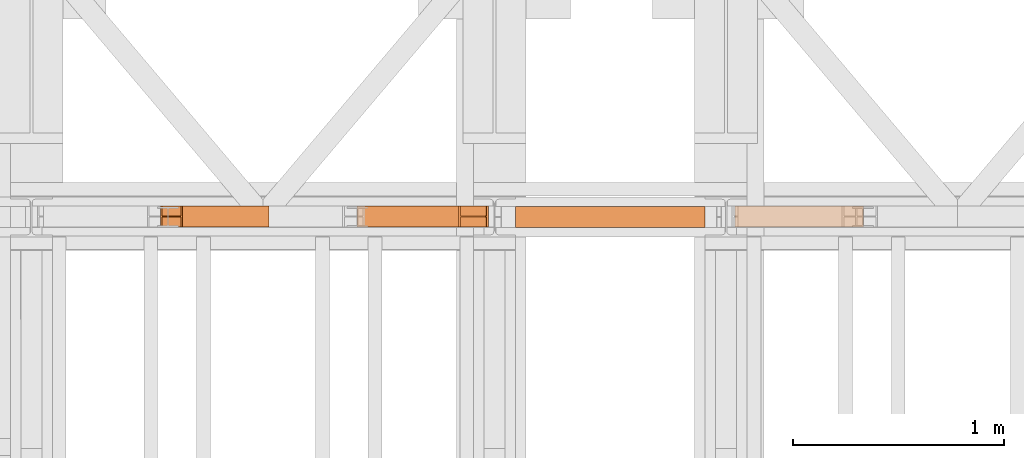
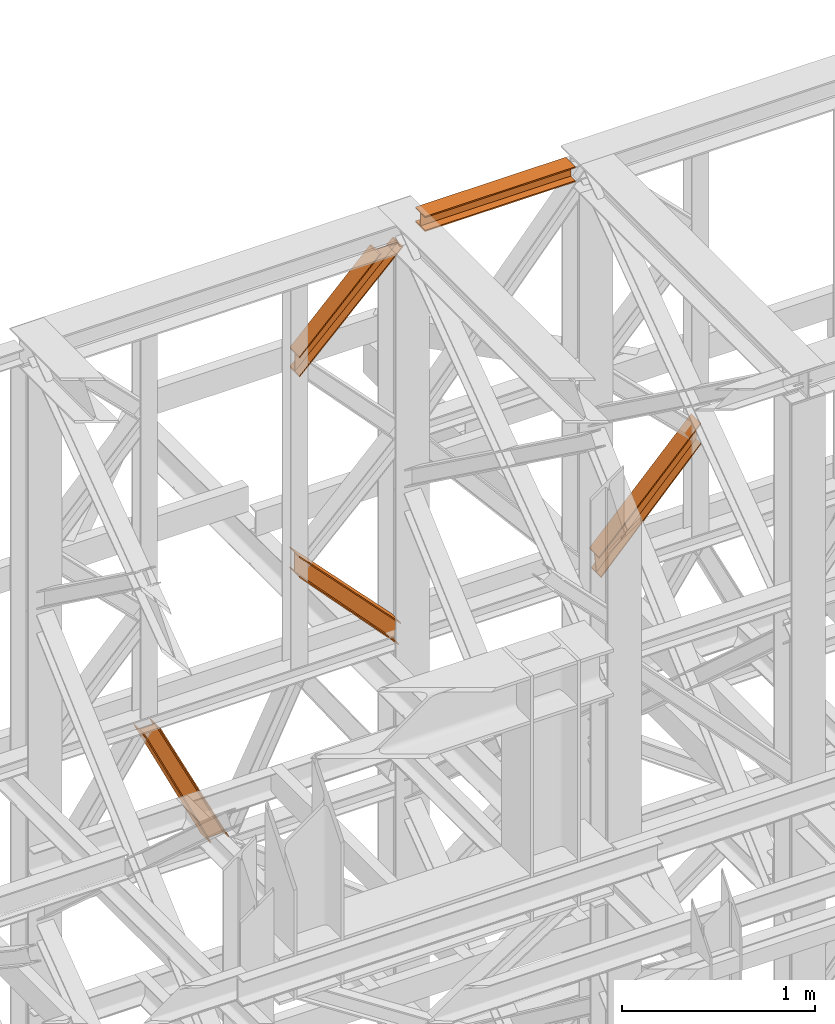
# One storey, part 205 of 208: 6 proxies.
"""IFC2X3 building model written with IfcOpenShell, lengths in millimetres."""

from ifc_helpers import new_model, entity, si_unit, converted_unit, frame, origin, origin_with_axes, place, context, subcontext, project, spatial, faceted_brep, element, save


model = new_model("IFC2X3")

# Units and contexts
model_context = context("Model", 3, precision=1e-05, world=origin())
plan_context = context("Plan", 3, precision=1e-05, world=origin())
body_context = subcontext(model_context, "Body", "Model", "MODEL_VIEW")
ifc_project = project(units=[si_unit("LENGTHUNIT", "METRE", prefix="MILLI"), converted_unit("PLANEANGLEUNIT", "DEGREE", entity("IfcPlaneAngleMeasure", 0.0174532925199433), si_unit("PLANEANGLEUNIT", "RADIAN"), dimensions=[0, 0, 0, 0, 0, 0, 0]), si_unit("AREAUNIT", "SQUARE_METRE"), si_unit("VOLUMEUNIT", "CUBIC_METRE")], contexts=[model_context, plan_context])

# Building, storey
building_placement = place(None, origin())
building = spatial("IfcBuilding", under=ifc_project, at=building_placement, CompositionType="COMPLEX")
storey_placement = place(building_placement, origin_with_axes())
storey = spatial("IfcBuildingStorey", under=building, at=storey_placement, Name="Geschoss", CompositionType="ELEMENT")

# Proxies
proxy_1_placement = place(storey_placement, frame((5593.254970018782, -13812.50587051043, 12300.47045114381), z_axis=(0.0, 0.0, 1.0), x_axis=(1.0, 0.0, 0.0)))
element("IfcBuildingElementProxy", 1, at=proxy_1_placement, inside=storey, context=body_context, shape_type="Brep", body=[
    faceted_brep([(900.009997019768, 0.01000000000021828, 88.01000000000022), (900.009997019768, 0.01000000000021828, 96.01000000000022), (900.009997019768, 100.0100000000002, 96.01000000000022), (900.009997019768, 100.0100000000002, 88.01000000000022), (900.009997019768, 52.51000000000022, 88.01000000000022), (900.009997019768, 52.51000000000022, 8.010000000000218), (900.009997019768, 100.0100000000002, 8.010000000000218), (900.009997019768, 100.0100000000002, 0.01000000000021828), (900.009997019768, 0.01000000000021828, 0.01000000000021828), (900.009997019768, 0.01000000000021828, 8.010000000000218), (900.009997019768, 47.51000000000022, 8.010000000000218), (900.009997019768, 47.51000000000022, 88.01000000000022), (900.009997019768, 0.01000000000021828, 96.01000000000022), (900.009997019768, 0.01000000000021828, 88.01000000000022), (0.01000000000021828, 0.01000000000385626, 88.01000000000022), (0.01000000000021828, 0.01000000000385626, 96.01000000000022), (900.009997019768, 100.0100000000002, 96.01000000000022), (900.009997019768, 0.01000000000021828, 96.01000000000022), (0.01000000000021828, 0.01000000000385626, 96.01000000000022), (0.01000000000021828, 100.0100000000039, 96.01000000000022), (900.009997019768, 100.0100000000002, 88.01000000000022), (900.009997019768, 100.0100000000002, 96.01000000000022), (0.01000000000021828, 100.0100000000039, 96.01000000000022), (0.01000000000021828, 100.0100000000039, 88.01000000000022), (900.009997019768, 52.51000000000022, 88.01000000000022), (900.009997019768, 100.0100000000002, 88.01000000000022), (0.01000000000021828, 100.0100000000039, 88.01000000000022), (0.01000000000021828, 52.51000000000386, 88.01000000000022), (900.009997019768, 52.51000000000022, 8.010000000000218), (900.009997019768, 52.51000000000022, 88.01000000000022), (0.01000000000021828, 52.51000000000386, 88.01000000000022), (0.01000000000021828, 52.51000000000386, 8.010000000000218), (900.009997019768, 100.0100000000002, 8.010000000000218), (900.009997019768, 52.51000000000022, 8.010000000000218), (0.01000000000021828, 52.51000000000386, 8.010000000000218), (0.01000000000021828, 100.0100000000039, 8.010000000000218), (900.009997019768, 100.0100000000002, 0.01000000000021828), (900.009997019768, 100.0100000000002, 8.010000000000218), (0.01000000000021828, 100.0100000000039, 8.010000000000218), (0.01000000000021828, 100.0100000000039, 0.01000000000021828), (900.009997019768, 0.01000000000021828, 0.01000000000021828), (900.009997019768, 100.0100000000002, 0.01000000000021828), (0.01000000000021828, 100.0100000000039, 0.01000000000021828), (0.01000000000021828, 0.01000000000385626, 0.01000000000021828), (900.009997019768, 0.01000000000021828, 8.010000000000218), (900.009997019768, 0.01000000000021828, 0.01000000000021828), (0.01000000000021828, 0.01000000000385626, 0.01000000000021828), (0.01000000000021828, 0.01000000000385626, 8.010000000000218), (900.009997019768, 47.51000000000022, 8.010000000000218), (900.009997019768, 0.01000000000021828, 8.010000000000218), (0.01000000000021828, 0.01000000000385626, 8.010000000000218), (0.01000000000021828, 47.51000000000386, 8.010000000000218), (900.009997019768, 47.51000000000022, 88.01000000000022), (900.009997019768, 47.51000000000022, 8.010000000000218), (0.01000000000021828, 47.51000000000386, 8.010000000000218), (0.01000000000021828, 47.51000000000386, 88.01000000000022), (900.009997019768, 0.01000000000021828, 88.01000000000022), (900.009997019768, 47.51000000000022, 88.01000000000022), (0.01000000000021828, 47.51000000000386, 88.01000000000022), (0.01000000000021828, 0.01000000000385626, 88.01000000000022), (0.01000000000021828, 0.01000000000385626, 88.01000000000022), (0.01000000000021828, 47.51000000000386, 88.01000000000022), (0.01000000000021828, 47.51000000000386, 8.010000000000218), (0.01000000000021828, 0.01000000000385626, 8.010000000000218), (0.01000000000021828, 0.01000000000385626, 0.01000000000021828), (0.01000000000021828, 100.0100000000039, 0.01000000000021828), (0.01000000000021828, 100.0100000000039, 8.010000000000218), (0.01000000000021828, 52.51000000000386, 8.010000000000218), (0.01000000000021828, 52.51000000000386, 88.01000000000022), (0.01000000000021828, 100.0100000000039, 88.01000000000022), (0.01000000000021828, 100.0100000000039, 96.01000000000022), (0.01000000000021828, 0.01000000000385626, 96.01000000000022)], [[[0, 1, 2, 3, 4, 5, 6, 7, 8, 9, 10, 11]], [[12, 13, 14, 15]], [[16, 17, 18, 19]], [[20, 21, 22, 23]], [[24, 25, 26, 27]], [[28, 29, 30, 31]], [[32, 33, 34, 35]], [[36, 37, 38, 39]], [[40, 41, 42, 43]], [[44, 45, 46, 47]], [[48, 49, 50, 51]], [[52, 53, 54, 55]], [[56, 57, 58, 59]], [[60, 61, 62, 63, 64, 65, 66, 67, 68, 69, 70, 71]]], orient=[[False], [False], [False], [False], [False], [False], [False], [False], [False], [False], [False], [False], [False], [False]]),
])
proxy_2_placement = place(storey_placement, frame((5593.254970018782, -13812.50587051042, 12300.47045114381), z_axis=(0.0, 0.0, 1.0), x_axis=(1.0, 0.0, 0.0)))
element("IfcBuildingElementProxy", 2, at=proxy_2_placement, inside=storey, context=body_context, shape_type="Brep", body=[
    faceted_brep([(900.009997019768, 0.01000000000021828, 88.01000000000022), (900.009997019768, 0.01000000000021828, 96.01000000000022), (900.009997019768, 100.0100000000002, 96.01000000000022), (900.009997019768, 100.0100000000002, 88.01000000000022), (900.009997019768, 52.51000000000022, 88.01000000000022), (900.009997019768, 52.51000000000022, 8.010000000000218), (900.009997019768, 100.0100000000002, 8.010000000000218), (900.009997019768, 100.0100000000002, 0.01000000000021828), (900.009997019768, 0.01000000000021828, 0.01000000000021828), (900.009997019768, 0.01000000000021828, 8.010000000000218), (900.009997019768, 47.51000000000022, 8.010000000000218), (900.009997019768, 47.51000000000022, 88.01000000000022), (900.009997019768, 0.01000000000021828, 96.01000000000022), (900.009997019768, 0.01000000000021828, 88.01000000000022), (0.01000000000021828, 0.01000000000385626, 88.01000000000022), (0.01000000000021828, 0.01000000000385626, 96.01000000000022), (900.009997019768, 100.0100000000002, 96.01000000000022), (900.009997019768, 0.01000000000021828, 96.01000000000022), (0.01000000000021828, 0.01000000000385626, 96.01000000000022), (0.01000000000021828, 100.0100000000039, 96.01000000000022), (900.009997019768, 100.0100000000002, 88.01000000000022), (900.009997019768, 100.0100000000002, 96.01000000000022), (0.01000000000021828, 100.0100000000039, 96.01000000000022), (0.01000000000021828, 100.0100000000039, 88.01000000000022), (900.009997019768, 52.51000000000022, 88.01000000000022), (900.009997019768, 100.0100000000002, 88.01000000000022), (0.01000000000021828, 100.0100000000039, 88.01000000000022), (0.01000000000021828, 52.51000000000386, 88.01000000000022), (900.009997019768, 52.51000000000022, 8.010000000000218), (900.009997019768, 52.51000000000022, 88.01000000000022), (0.01000000000021828, 52.51000000000386, 88.01000000000022), (0.01000000000021828, 52.51000000000386, 8.010000000000218), (900.009997019768, 100.0100000000002, 8.010000000000218), (900.009997019768, 52.51000000000022, 8.010000000000218), (0.01000000000021828, 52.51000000000386, 8.010000000000218), (0.01000000000021828, 100.0100000000039, 8.010000000000218), (900.009997019768, 100.0100000000002, 0.01000000000021828), (900.009997019768, 100.0100000000002, 8.010000000000218), (0.01000000000021828, 100.0100000000039, 8.010000000000218), (0.01000000000021828, 100.0100000000039, 0.01000000000021828), (900.009997019768, 0.01000000000021828, 0.01000000000021828), (900.009997019768, 100.0100000000002, 0.01000000000021828), (0.01000000000021828, 100.0100000000039, 0.01000000000021828), (0.01000000000021828, 0.01000000000385626, 0.01000000000021828), (900.009997019768, 0.01000000000021828, 8.010000000000218), (900.009997019768, 0.01000000000021828, 0.01000000000021828), (0.01000000000021828, 0.01000000000385626, 0.01000000000021828), (0.01000000000021828, 0.01000000000385626, 8.010000000000218), (900.009997019768, 47.51000000000022, 8.010000000000218), (900.009997019768, 0.01000000000021828, 8.010000000000218), (0.01000000000021828, 0.01000000000385626, 8.010000000000218), (0.01000000000021828, 47.51000000000386, 8.010000000000218), (900.009997019768, 47.51000000000022, 88.01000000000022), (900.009997019768, 47.51000000000022, 8.010000000000218), (0.01000000000021828, 47.51000000000386, 8.010000000000218), (0.01000000000021828, 47.51000000000386, 88.01000000000022), (900.009997019768, 0.01000000000021828, 88.01000000000022), (900.009997019768, 47.51000000000022, 88.01000000000022), (0.01000000000021828, 47.51000000000386, 88.01000000000022), (0.01000000000021828, 0.01000000000385626, 88.01000000000022), (0.01000000000021828, 0.01000000000385626, 88.01000000000022), (0.01000000000021828, 47.51000000000386, 88.01000000000022), (0.01000000000021828, 47.51000000000386, 8.010000000000218), (0.01000000000021828, 0.01000000000385626, 8.010000000000218), (0.01000000000021828, 0.01000000000385626, 0.01000000000021828), (0.01000000000021828, 100.0100000000039, 0.01000000000021828), (0.01000000000021828, 100.0100000000039, 8.010000000000218), (0.01000000000021828, 52.51000000000386, 8.010000000000218), (0.01000000000021828, 52.51000000000386, 88.01000000000022), (0.01000000000021828, 100.0100000000039, 88.01000000000022), (0.01000000000021828, 100.0100000000039, 96.01000000000022), (0.01000000000021828, 0.01000000000385626, 96.01000000000022)], [[[0, 1, 2, 3, 4, 5, 6, 7, 8, 9, 10, 11]], [[12, 13, 14, 15]], [[16, 17, 18, 19]], [[20, 21, 22, 23]], [[24, 25, 26, 27]], [[28, 29, 30, 31]], [[32, 33, 34, 35]], [[36, 37, 38, 39]], [[40, 41, 42, 43]], [[44, 45, 46, 47]], [[48, 49, 50, 51]], [[52, 53, 54, 55]], [[56, 57, 58, 59]], [[60, 61, 62, 63, 64, 65, 66, 67, 68, 69, 70, 71]]], orient=[[False], [False], [False], [False], [False], [False], [False], [False], [False], [False], [False], [False], [False], [False]]),
])
proxy_3_placement = place(storey_placement, frame((4840.754968528663, -13810.57439404318, 9738.383764068489), z_axis=(0.0, 0.0, 1.0), x_axis=(1.0, 0.0, 0.0)))
element("IfcBuildingElementProxy", 3, at=proxy_3_placement, inside=storey, context=body_context, shape_type="Brep", body=[
    faceted_brep([(609.3389392297795, 0.01000000000021828, 127.1336120970282), (0.01000000000203727, 0.01000000000021828, 762.0805165043985), (0.01000000000203727, 0.01000000000021828, 772.1793707618835), (610.1904194102481, 0.01000000000021828, 135.4554138886069), (610.1904194102481, 0.01000000000021828, 135.4554138886069), (0.01000000000203727, 0.01000000000021828, 772.1793707618835), (0.01000000000294676, 100.0100000000002, 772.1793707618799), (610.1904194102481, 100.0100000000002, 135.4554138886069), (610.1904194102481, 100.0100000000002, 135.4554138886069), (0.01000000000294676, 100.0100000000002, 772.1793707618799), (0.01000000000203727, 100.0100000000002, 762.0805165043985), (609.3389392297795, 100.0100000000002, 127.1336120970282), (609.3389392297795, 100.0100000000002, 127.1336120970282), (0.01000000000203727, 100.0100000000002, 762.0805165043985), (0.01000000000203727, 52.51000000000022, 762.0805165043985), (609.3389392297795, 52.51000000000022, 127.1336120970282), (609.3389392297795, 52.51000000000022, 127.1336120970282), (0.01000000000203727, 52.51000000000022, 762.0805165043985), (0.01000000000112777, 52.51000000000022, 645.5811508176976), (597.1830768457185, 52.51000000000022, 8.330286210673876), (597.1830768457185, 52.51000000000022, 8.330286210673876), (0.01000000000112777, 52.51000000000022, 645.5811508176976), (0.009999999999308784, 100.0100000000002, 645.5811508177048), (597.1830768457185, 100.0100000000002, 8.330286210677514), (597.1830768457185, 100.0100000000002, 8.330286210677514), (0.009999999999308784, 100.0100000000002, 645.5811508177048), (0.01000000000203727, 100.0100000000002, 635.4780302121417), (596.3317517382911, 100.0100000000002, 0.01000000000021828), (596.3317517382911, 100.0100000000002, 0.01000000000021828), (0.01000000000203727, 100.0100000000002, 635.4780302121417), (0.01000000000294676, 0.01000000000021828, 635.4780302121417), (596.3317517382902, 0.01000000000021828, 0.01000000000021828), (596.3317517382902, 0.01000000000021828, 0.01000000000021828), (0.01000000000294676, 0.01000000000021828, 635.4780302121417), (0.01000000000112777, 0.01000000000021828, 645.5811508177048), (597.1830768457185, 0.01000000000021828, 8.330286210677514), (597.1830768457185, 0.01000000000021828, 8.330286210677514), (0.01000000000112777, 0.01000000000021828, 645.5811508177048), (0.01000000000203727, 47.51000000000022, 645.5811508177048), (597.1830768457194, 47.51000000000022, 8.330286210681152), (597.1830768457194, 47.51000000000022, 8.330286210681152), (0.01000000000203727, 47.51000000000022, 645.5811508177048), (0.01000000000203727, 47.51000000000022, 762.0805165043985), (609.3389392297795, 47.51000000000022, 127.1336120970282), (609.3389392297795, 47.51000000000022, 127.1336120970282), (0.01000000000203727, 47.51000000000022, 762.0805165043985), (0.01000000000203727, 0.01000000000021828, 762.0805165043985), (609.3389392297795, 0.01000000000021828, 127.1336120970282), (610.1904194102481, 0.01000000000021828, 135.4554138886069), (610.1904194102481, 100.0100000000002, 135.4554138886069), (609.3389392297795, 100.0100000000002, 127.1336120970282), (609.3389392297795, 52.51000000000022, 127.1336120970282), (597.1830768457185, 52.51000000000022, 8.330286210673876), (597.1830768457185, 100.0100000000002, 8.330286210677514), (596.3317517382911, 100.0100000000002, 0.01000000000021828), (596.3317517382902, 0.01000000000021828, 0.01000000000021828), (597.1830768457185, 0.01000000000021828, 8.330286210677514), (597.1830768457194, 47.51000000000022, 8.330286210681152), (609.3389392297795, 47.51000000000022, 127.1336120970282), (609.3389392297795, 0.01000000000021828, 127.1336120970282), (0.01000000000203727, 0.01000000000021828, 762.0805165043985), (0.01000000000203727, 47.51000000000022, 762.0805165043985), (0.01000000000203727, 47.51000000000022, 645.5811508177048), (0.01000000000112777, 0.01000000000021828, 645.5811508177048), (0.01000000000294676, 0.01000000000021828, 635.4780302121417), (0.01000000000203727, 100.0100000000002, 635.4780302121417), (0.009999999999308784, 100.0100000000002, 645.5811508177048), (0.01000000000112777, 52.51000000000022, 645.5811508176976), (0.01000000000203727, 52.51000000000022, 762.0805165043985), (0.01000000000203727, 100.0100000000002, 762.0805165043985), (0.01000000000294676, 100.0100000000002, 772.1793707618799), (0.01000000000203727, 0.01000000000021828, 772.1793707618835)], [[[0, 1, 2, 3]], [[4, 5, 6, 7]], [[8, 9, 10, 11]], [[12, 13, 14, 15]], [[16, 17, 18, 19]], [[20, 21, 22, 23]], [[24, 25, 26, 27]], [[28, 29, 30, 31]], [[32, 33, 34, 35]], [[36, 37, 38, 39]], [[40, 41, 42, 43]], [[44, 45, 46, 47]], [[48, 49, 50, 51, 52, 53, 54, 55, 56, 57, 58, 59]], [[60, 61, 62, 63, 64, 65, 66, 67, 68, 69, 70, 71]]], orient=[[False], [False], [False], [False], [False], [False], [False], [False], [False], [False], [False], [False], [False], [False]]),
])
proxy_4_placement = place(storey_placement, frame((4843.254968528664, -13810.57439404318, 11640.28097264272), z_axis=(0.0, 0.0, 1.0), x_axis=(1.0, 0.0, 0.0)))
element("IfcBuildingElementProxy", 4, at=proxy_4_placement, inside=storey, context=body_context, shape_type="Brep", body=[
    faceted_brep([(487.7698797118947, 0.01000000000021828, 609.7190860510873), (0.01000000000112777, 0.01000000000021828, 120.9016769489845), (0.01000000000112777, 0.01000000000021828, 130.8127730178949), (478.5483619653533, 0.01000000000021828, 609.7190860510873), (478.5483619653533, 0.01000000000021828, 609.7190860510873), (0.01000000000112777, 0.01000000000021828, 130.8127730178949), (0.01000000000476575, 100.0100000000002, 130.8127730179022), (478.5483619653523, 100.0100000000002, 609.7190860510873), (478.5483619653523, 100.0100000000002, 609.7190860510873), (0.01000000000476575, 100.0100000000002, 130.8127730179022), (0.01000000000112777, 100.0100000000002, 120.9016769489845), (487.7698797118947, 100.0100000000002, 609.7190860510873), (487.7698797118947, 100.0100000000002, 609.7190860510873), (0.01000000000112777, 100.0100000000002, 120.9016769489845), (0.01000000000021828, 52.51000000000022, 120.9016769489808), (487.7698797118956, 52.51000000000022, 609.7190860510873), (487.7698797118956, 52.51000000000022, 609.7190860510873), (0.01000000000021828, 52.51000000000022, 120.9016769489808), (0.01000000000112777, 52.51000000000022, 9.871029833511784), (612.940508044323, 52.51000000000022, 609.7190860510873), (612.940508044323, 52.51000000000022, 609.7190860510873), (0.01000000000112777, 52.51000000000022, 9.871029833511784), (0.01000000000112777, 100.0100000000002, 9.871029833511784), (612.9405080443221, 100.0100000000002, 609.7190860510909), (612.9405080443221, 100.0100000000002, 609.7190860510909), (0.01000000000112777, 100.0100000000002, 9.871029833511784), (0.01000000000112777, 100.0100000000002, 0.01000000000021828), (622.1621300498173, 100.0100000000002, 609.7190860510909), (622.1621300498173, 100.0100000000002, 609.7190860510909), (0.01000000000112777, 100.0100000000002, 0.01000000000021828), (0.01000000000112777, 0.01000000000021828, 0.01000000000021828), (622.1621300498127, 0.01000000000021828, 609.7190860510837), (622.1621300498127, 0.01000000000021828, 609.7190860510837), (0.01000000000112777, 0.01000000000021828, 0.01000000000021828), (0.01000000000112777, 0.01000000000021828, 9.871029833511784), (612.9405080443157, 0.01000000000021828, 609.7190860510873), (612.9405080443157, 0.01000000000021828, 609.7190860510873), (0.01000000000112777, 0.01000000000021828, 9.871029833511784), (0.01000000000112777, 47.51000000000022, 9.871029833511784), (612.9405080443194, 47.51000000000022, 609.7190860510909), (612.9405080443194, 47.51000000000022, 609.7190860510909), (0.01000000000112777, 47.51000000000022, 9.871029833511784), (0.01000000000112777, 47.51000000000022, 120.9016769489845), (487.7698797118947, 47.51000000000022, 609.7190860510873), (487.7698797118947, 47.51000000000022, 609.7190860510873), (0.01000000000112777, 47.51000000000022, 120.9016769489845), (0.01000000000112777, 0.01000000000021828, 120.9016769489845), (487.7698797118947, 0.01000000000021828, 609.7190860510873), (0.01000000000112777, 0.01000000000021828, 120.9016769489845), (0.01000000000112777, 47.51000000000022, 120.9016769489845), (0.01000000000112777, 47.51000000000022, 9.871029833511784), (0.01000000000112777, 0.01000000000021828, 9.871029833511784), (0.01000000000112777, 0.01000000000021828, 0.01000000000021828), (0.01000000000112777, 100.0100000000002, 0.01000000000021828), (0.01000000000112777, 100.0100000000002, 9.871029833511784), (0.01000000000112777, 52.51000000000022, 9.871029833511784), (0.01000000000021828, 52.51000000000022, 120.9016769489808), (0.01000000000112777, 100.0100000000002, 120.9016769489845), (0.01000000000476575, 100.0100000000002, 130.8127730179022), (0.01000000000112777, 0.01000000000021828, 130.8127730178949), (478.5483619653533, 0.01000000000021828, 609.7190860510873), (478.5483619653523, 100.0100000000002, 609.7190860510873), (487.7698797118947, 100.0100000000002, 609.7190860510873), (487.7698797118956, 52.51000000000022, 609.7190860510873), (612.940508044323, 52.51000000000022, 609.7190860510873), (612.9405080443221, 100.0100000000002, 609.7190860510909), (622.1621300498173, 100.0100000000002, 609.7190860510909), (622.1621300498127, 0.01000000000021828, 609.7190860510837), (612.9405080443157, 0.01000000000021828, 609.7190860510873), (612.9405080443194, 47.51000000000022, 609.7190860510909), (487.7698797118947, 47.51000000000022, 609.7190860510873), (487.7698797118947, 0.01000000000021828, 609.7190860510873)], [[[0, 1, 2, 3]], [[4, 5, 6, 7]], [[8, 9, 10, 11]], [[12, 13, 14, 15]], [[16, 17, 18, 19]], [[20, 21, 22, 23]], [[24, 25, 26, 27]], [[28, 29, 30, 31]], [[32, 33, 34, 35]], [[36, 37, 38, 39]], [[40, 41, 42, 43]], [[44, 45, 46, 47]], [[48, 49, 50, 51, 52, 53, 54, 55, 56, 57, 58, 59]], [[60, 61, 62, 63, 64, 65, 66, 67, 68, 69, 70, 71]]], orient=[[False], [False], [False], [False], [False], [False], [False], [False], [False], [False], [False], [False], [False], [False]]),
])
proxy_5_placement = place(storey_placement, frame((6635.574549118421, -13810.57439404318, 9738.383764068489), z_axis=(0.0, 0.0, 1.0), x_axis=(1.0, 0.0, 0.0)))
element("IfcBuildingElementProxy", 5, at=proxy_5_placement, inside=storey, context=body_context, shape_type="Brep", body=[
    faceted_brep([(0.8614801804687886, 0.01000000000021828, 127.1336120970282), (0.01000000000021828, 0.01000000000021828, 135.4554138886069), (610.1904194102472, 0.01000000000021828, 772.1793707618835), (610.1904194102472, 0.01000000000021828, 762.0805165043985), (0.01000000000021828, 0.01000000000021828, 135.4554138886069), (0.01000000000021828, 100.0100000000002, 135.4554138886069), (610.1904194102462, 100.0100000000002, 772.1793707618799), (610.1904194102472, 0.01000000000021828, 772.1793707618835), (0.01000000000021828, 100.0100000000002, 135.4554138886069), (0.8614801804687886, 100.0100000000002, 127.1336120970282), (610.1904194102472, 100.0100000000002, 762.0805165043985), (610.1904194102462, 100.0100000000002, 772.1793707618799), (0.8614801804687886, 100.0100000000002, 127.1336120970282), (0.8614801804687886, 52.51000000000022, 127.1336120970282), (610.1904194102472, 52.51000000000022, 762.0805165043985), (610.1904194102472, 100.0100000000002, 762.0805165043985), (0.8614801804687886, 52.51000000000022, 127.1336120970282), (13.01734256452983, 52.51000000000022, 8.330286210673876), (610.1904194102472, 52.51000000000022, 645.5811508176976), (610.1904194102472, 52.51000000000022, 762.0805165043985), (13.01734256452983, 52.51000000000022, 8.330286210673876), (13.01734256452983, 100.0100000000002, 8.330286210677514), (610.1904194102499, 100.0100000000002, 645.5811508177048), (610.1904194102472, 52.51000000000022, 645.5811508176976), (13.01734256452983, 100.0100000000002, 8.330286210677514), (13.86866767195716, 100.0100000000002, 0.01000000000021828), (610.1904194102472, 100.0100000000002, 635.4780302121417), (610.1904194102499, 100.0100000000002, 645.5811508177048), (13.86866767195716, 100.0100000000002, 0.01000000000021828), (13.86866767195807, 0.01000000000021828, 0.01000000000021828), (610.1904194102462, 0.01000000000021828, 635.4780302121417), (610.1904194102472, 100.0100000000002, 635.4780302121417), (13.86866767195807, 0.01000000000021828, 0.01000000000021828), (13.01734256452983, 0.01000000000021828, 8.330286210677514), (610.1904194102472, 0.01000000000021828, 645.5811508177048), (610.1904194102462, 0.01000000000021828, 635.4780302121417), (13.01734256452983, 0.01000000000021828, 8.330286210677514), (13.01734256452892, 47.51000000000022, 8.330286210681152), (610.1904194102462, 47.51000000000022, 645.5811508177048), (610.1904194102472, 0.01000000000021828, 645.5811508177048), (13.01734256452892, 47.51000000000022, 8.330286210681152), (0.8614801804687886, 47.51000000000022, 127.1336120970282), (610.1904194102472, 47.51000000000022, 762.0805165043985), (610.1904194102462, 47.51000000000022, 645.5811508177048), (0.8614801804687886, 47.51000000000022, 127.1336120970282), (0.8614801804687886, 0.01000000000021828, 127.1336120970282), (610.1904194102472, 0.01000000000021828, 762.0805165043985), (610.1904194102472, 47.51000000000022, 762.0805165043985), (0.01000000000021828, 0.01000000000021828, 135.4554138886069), (0.8614801804687886, 0.01000000000021828, 127.1336120970282), (0.8614801804687886, 47.51000000000022, 127.1336120970282), (13.01734256452892, 47.51000000000022, 8.330286210681152), (13.01734256452983, 0.01000000000021828, 8.330286210677514), (13.86866767195807, 0.01000000000021828, 0.01000000000021828), (13.86866767195716, 100.0100000000002, 0.01000000000021828), (13.01734256452983, 100.0100000000002, 8.330286210677514), (13.01734256452983, 52.51000000000022, 8.330286210673876), (0.8614801804687886, 52.51000000000022, 127.1336120970282), (0.8614801804687886, 100.0100000000002, 127.1336120970282), (0.01000000000021828, 100.0100000000002, 135.4554138886069), (610.1904194102472, 0.01000000000021828, 762.0805165043985), (610.1904194102472, 0.01000000000021828, 772.1793707618835), (610.1904194102462, 100.0100000000002, 772.1793707618799), (610.1904194102472, 100.0100000000002, 762.0805165043985), (610.1904194102472, 52.51000000000022, 762.0805165043985), (610.1904194102472, 52.51000000000022, 645.5811508176976), (610.1904194102499, 100.0100000000002, 645.5811508177048), (610.1904194102472, 100.0100000000002, 635.4780302121417), (610.1904194102462, 0.01000000000021828, 635.4780302121417), (610.1904194102472, 0.01000000000021828, 645.5811508177048), (610.1904194102462, 47.51000000000022, 645.5811508177048), (610.1904194102472, 47.51000000000022, 762.0805165043985)], [[[0, 1, 2, 3]], [[4, 5, 6, 7]], [[8, 9, 10, 11]], [[12, 13, 14, 15]], [[16, 17, 18, 19]], [[20, 21, 22, 23]], [[24, 25, 26, 27]], [[28, 29, 30, 31]], [[32, 33, 34, 35]], [[36, 37, 38, 39]], [[40, 41, 42, 43]], [[44, 45, 46, 47]], [[48, 49, 50, 51, 52, 53, 54, 55, 56, 57, 58, 59]], [[60, 61, 62, 63, 64, 65, 66, 67, 68, 69, 70, 71]]], orient=[[False], [False], [False], [False], [False], [False], [False], [False], [False], [False], [False], [False], [False], [False]]),
])
proxy_6_placement = place(storey_placement, frame((3906.920491684339, -13810.57439404318, 8881.007354628784), z_axis=(0.0, 0.0, 1.0), x_axis=(1.0, 0.0, 0.0)))
element("IfcBuildingElementProxy", 6, at=proxy_6_placement, inside=storey, context=body_context, shape_type="Brep", body=[
    faceted_brep([(515.1363869069501, 0.01000000000021828, 0.01000000000021828), (507.9473177084756, 0.01000000000021828, 0.01000000000021828), (97.49508042920752, 0.01000000000021828, 829.1083585935612), (105.1910810543704, 0.01000000000021828, 829.1083585935612), (515.1363869069492, 100.0100000000002, 0.01000000000021828), (515.1363869069501, 0.01000000000021828, 0.01000000000021828), (105.1910810543704, 0.01000000000021828, 829.1083585935612), (105.1910810543673, 100.0100000000002, 829.1083585935612), (507.9473177084756, 100.0100000000002, 0.01000000000021828), (515.1363869069492, 100.0100000000002, 0.01000000000021828), (105.1910810543673, 100.0100000000002, 829.1083585935612), (97.49508042920752, 100.0100000000002, 829.1083585935612), (507.9473177084756, 52.51000000000022, 0.01000000000385626), (507.9473177084756, 100.0100000000002, 0.01000000000021828), (97.49508042920752, 100.0100000000002, 829.1083585935612), (97.49508042920752, 52.51000000000022, 829.1083585935612), (409.4818461420691, 52.51000000000022, 0.01000000000021828), (507.9473177084756, 52.51000000000022, 0.01000000000385626), (97.49508042920752, 52.51000000000022, 829.1083585935612), (7.688350677078688, 52.51000000000022, 829.1083585935612), (409.4818461420718, 100.0100000000002, 0.01000000000021828), (409.4818461420691, 52.51000000000022, 0.01000000000021828), (7.688350677078688, 52.51000000000022, 829.1083585935612), (7.688350677081871, 100.0100000000002, 829.1083585935612), (402.3010046401523, 100.0100000000002, 0.01000000000021828), (409.4818461420718, 100.0100000000002, 0.01000000000021828), (7.688350677081871, 100.0100000000002, 829.1083585935612), (0.01000000000021828, 100.0100000000002, 829.1083585935612), (402.3010046401523, 0.01000000000021828, 0.01000000000021828), (402.3010046401523, 100.0100000000002, 0.01000000000021828), (0.01000000000021828, 100.0100000000002, 829.1083585935612), (0.01000000000021828, 0.01000000000021828, 829.1083585935612), (409.4818461420718, 0.01000000000021828, 0.01000000000021828), (402.3010046401523, 0.01000000000021828, 0.01000000000021828), (0.01000000000021828, 0.01000000000021828, 829.1083585935612), (7.68835067708369, 0.01000000000021828, 829.1083585935612), (409.4818461420737, 47.51000000000022, 0.01000000000021828), (409.4818461420718, 0.01000000000021828, 0.01000000000021828), (7.68835067708369, 0.01000000000021828, 829.1083585935612), (7.68835067708369, 47.51000000000022, 829.1083585935612), (507.9473177084756, 47.51000000000022, 0.01000000000385626), (409.4818461420737, 47.51000000000022, 0.01000000000021828), (7.68835067708369, 47.51000000000022, 829.1083585935612), (97.49508042920752, 47.51000000000022, 829.1083585935612), (507.9473177084756, 0.01000000000021828, 0.01000000000021828), (507.9473177084756, 47.51000000000022, 0.01000000000385626), (97.49508042920752, 47.51000000000022, 829.1083585935612), (97.49508042920752, 0.01000000000021828, 829.1083585935612), (105.1910810543704, 0.01000000000021828, 829.1083585935612), (97.49508042920752, 0.01000000000021828, 829.1083585935612), (97.49508042920752, 47.51000000000022, 829.1083585935612), (7.68835067708369, 47.51000000000022, 829.1083585935612), (7.68835067708369, 0.01000000000021828, 829.1083585935612), (0.01000000000021828, 0.01000000000021828, 829.1083585935612), (0.01000000000021828, 100.0100000000002, 829.1083585935612), (7.688350677081871, 100.0100000000002, 829.1083585935612), (7.688350677078688, 52.51000000000022, 829.1083585935612), (97.49508042920752, 52.51000000000022, 829.1083585935612), (97.49508042920752, 100.0100000000002, 829.1083585935612), (105.1910810543673, 100.0100000000002, 829.1083585935612), (507.9473177084756, 0.01000000000021828, 0.01000000000021828), (515.1363869069501, 0.01000000000021828, 0.01000000000021828), (515.1363869069492, 100.0100000000002, 0.01000000000021828), (507.9473177084756, 100.0100000000002, 0.01000000000021828), (507.9473177084756, 52.51000000000022, 0.01000000000385626), (409.4818461420691, 52.51000000000022, 0.01000000000021828), (409.4818461420718, 100.0100000000002, 0.01000000000021828), (402.3010046401523, 100.0100000000002, 0.01000000000021828), (402.3010046401523, 0.01000000000021828, 0.01000000000021828), (409.4818461420718, 0.01000000000021828, 0.01000000000021828), (409.4818461420737, 47.51000000000022, 0.01000000000021828), (507.9473177084756, 47.51000000000022, 0.01000000000385626)], [[[0, 1, 2, 3]], [[4, 5, 6, 7]], [[8, 9, 10, 11]], [[12, 13, 14, 15]], [[16, 17, 18, 19]], [[20, 21, 22, 23]], [[24, 25, 26, 27]], [[28, 29, 30, 31]], [[32, 33, 34, 35]], [[36, 37, 38, 39]], [[40, 41, 42, 43]], [[44, 45, 46, 47]], [[48, 49, 50, 51, 52, 53, 54, 55, 56, 57, 58, 59]], [[60, 61, 62, 63, 64, 65, 66, 67, 68, 69, 70, 71]]], orient=[[False], [False], [False], [False], [False], [False], [False], [False], [False], [False], [False], [False], [False], [False]]),
])

save(model, "model.ifc")
